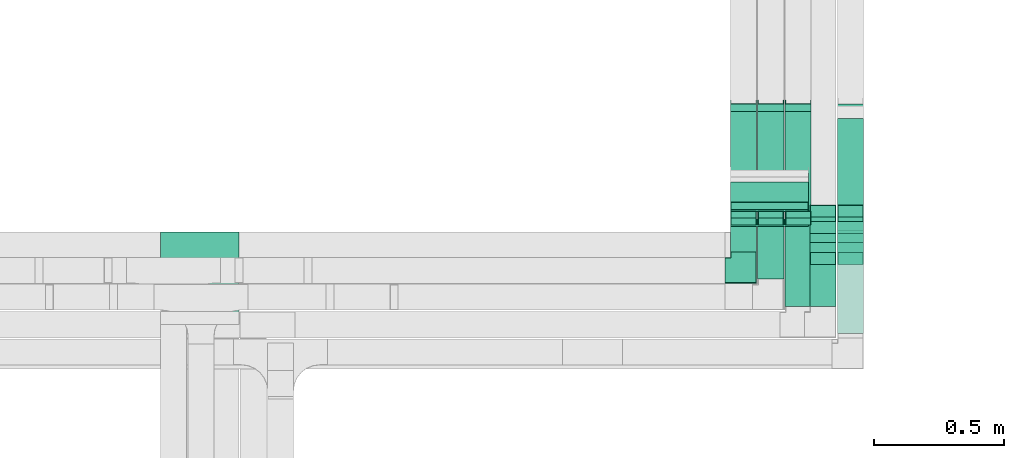
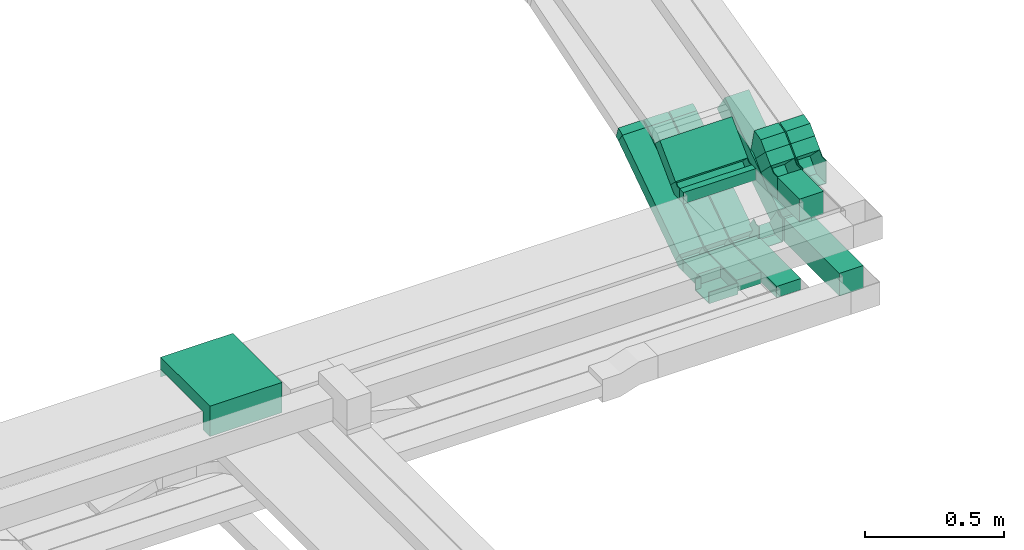
# One storey, part 8 of 18: 15 flow fittings, 13 flow segments.
"""IFC2X3 building model written with IfcOpenShell, lengths in millimetres."""

from ifc_helpers import new_model, entity, si_unit, converted_unit, derived_unit, direction, frame, frame_2d, origin, origin_2d_with_axis, place, context, subcontext, project, spatial, polyline, circle_curve, parameter, trimmed, segment, composite_curve, rectangle, outline, extrude, faceted_brep, source, transform, mapped, material, material_list, type_object, type_shapes, element, save


model = new_model("IFC2X3")

# Units and contexts
model_context = context("Model", 3, precision=0.01, world=origin(), true_north=direction((6.12303176911189e-17, 1.0)))
body_context = subcontext(model_context, "Body", "Model", "MODEL_VIEW")
ifc_project = project(units=[si_unit("LENGTHUNIT", "METRE", prefix="MILLI"), si_unit("AREAUNIT", "SQUARE_METRE"), si_unit("VOLUMEUNIT", "CUBIC_METRE"), converted_unit("PLANEANGLEUNIT", "DEGREE", entity("IfcRatioMeasure", 0.0174532925199433), si_unit("PLANEANGLEUNIT", "RADIAN"), dimensions=[0, 0, 0, 0, 0, 0, 0]), si_unit("MASSUNIT", "GRAM", prefix="KILO"), derived_unit("MASSDENSITYUNIT", [(si_unit("MASSUNIT", "GRAM", prefix="KILO"), 1), (si_unit("LENGTHUNIT", "METRE"), -3)]), derived_unit("MOMENTOFINERTIAUNIT", [(si_unit("LENGTHUNIT", "METRE"), 4)]), si_unit("TIMEUNIT", "SECOND"), si_unit("FREQUENCYUNIT", "HERTZ"), si_unit("THERMODYNAMICTEMPERATUREUNIT", "DEGREE_CELSIUS"), derived_unit("THERMALTRANSMITTANCEUNIT", [(si_unit("MASSUNIT", "GRAM", prefix="KILO"), 1), (si_unit("THERMODYNAMICTEMPERATUREUNIT", "KELVIN"), -1), (si_unit("TIMEUNIT", "SECOND"), -3)]), derived_unit("VOLUMETRICFLOWRATEUNIT", [(si_unit("LENGTHUNIT", "METRE"), 3), (si_unit("TIMEUNIT", "SECOND"), -1)]), derived_unit("MASSFLOWRATEUNIT", [(si_unit("MASSUNIT", "GRAM", prefix="KILO"), 1), (si_unit("TIMEUNIT", "SECOND"), -1)]), derived_unit("ROTATIONALFREQUENCYUNIT", [(si_unit("TIMEUNIT", "SECOND"), -1)]), si_unit("ELECTRICCURRENTUNIT", "AMPERE"), si_unit("ELECTRICVOLTAGEUNIT", "VOLT"), si_unit("POWERUNIT", "WATT"), si_unit("FORCEUNIT", "NEWTON", prefix="KILO"), si_unit("ILLUMINANCEUNIT", "LUX"), si_unit("LUMINOUSFLUXUNIT", "LUMEN"), si_unit("LUMINOUSINTENSITYUNIT", "CANDELA"), derived_unit("USERDEFINED", [(si_unit("MASSUNIT", "GRAM", prefix="KILO"), -1), (si_unit("LENGTHUNIT", "METRE"), -2), (si_unit("TIMEUNIT", "SECOND"), 3), (si_unit("LUMINOUSFLUXUNIT", "LUMEN"), 1)]), derived_unit("LINEARVELOCITYUNIT", [(si_unit("LENGTHUNIT", "METRE"), 1), (si_unit("TIMEUNIT", "SECOND"), -1)]), si_unit("PRESSUREUNIT", "PASCAL"), derived_unit("USERDEFINED", [(si_unit("LENGTHUNIT", "METRE"), -2), (si_unit("MASSUNIT", "GRAM", prefix="KILO"), 1), (si_unit("TIMEUNIT", "SECOND"), -2)]), derived_unit("LINEARFORCEUNIT", [(si_unit("MASSUNIT", "GRAM", prefix="KILO"), 1), (si_unit("LENGTHUNIT", "METRE"), 1), (si_unit("TIMEUNIT", "SECOND"), -2), (si_unit("LENGTHUNIT", "METRE"), -1)]), derived_unit("PLANARFORCEUNIT", [(si_unit("MASSUNIT", "GRAM", prefix="KILO"), 1), (si_unit("LENGTHUNIT", "METRE"), 1), (si_unit("TIMEUNIT", "SECOND"), -2), (si_unit("LENGTHUNIT", "METRE"), -2)])], contexts=[model_context])

# Site, building, storey
site_placement = place(None, frame((0.0, -0.00077364408347762, 0.0)))
site = spatial("IfcSite", under=ifc_project, at=site_placement, CompositionType="ELEMENT")
building_placement = place(site_placement, origin())
building = spatial("IfcBuilding", under=site, at=building_placement, CompositionType="ELEMENT")
storey_placement = place(building_placement, frame((0.0, 0.0, 19800.0)))
storey = spatial("IfcBuildingStorey", under=building, at=storey_placement, CompositionType="ELEMENT", Elevation=19800.0)

# Flow segments
cable_carrier_segment_type = type_object("IfcCableCarrierSegmentType", PredefinedType="CABLETRAYSEGMENT")
flow_segment_1_placement = place(storey_placement, frame((20600.2168010831, 9960.22583236333, 2600.0)))
element("IfcFlowSegment", 1, at=flow_segment_1_placement, inside=storey, type_object=cable_carrier_segment_type, context=body_context, shape_type="SweptSolid", body=[
    extrude(rectangle(XDim=396.146721820888, YDim=100.000000000003, at=frame_2d((0.0, 2.16715534406831e-12), x_axis=(1.0, 0.0))), frame((50.0, 198.073360910445, 0.0), z_axis=(0.0, 0.0, 1.0), x_axis=(0.0, 1.0, 0.0)), (0.0, 0.0, 1.0), 99.9999999999989),
])
flow_segment_2_placement = place(storey_placement, frame((20600.2168010831, 10396.2733517379, 2629.29514077132)))
element("IfcFlowSegment", 2, at=flow_segment_2_placement, inside=storey, type_object=cable_carrier_segment_type, context=body_context, shape_type="SweptSolid", body=[
    extrude(rectangle(XDim=100.000000000001, YDim=467.368346274404, at=frame_2d((-2.08899564313469e-12, -1.19371179607697e-12), x_axis=(0.0, 1.0))), frame((0.0, 221.692604815737, 172.12640989951), z_axis=(1.0, 0.0, 0.0), x_axis=(0.0, 0.829037572555048, 0.559192903470738)), (0.0, 0.0, 1.0), 100.000000000003),
])
flow_segment_3_placement = place(storey_placement, frame((20400.2168010831, 10064.235495744, 2600.0)))
element("IfcFlowSegment", 3, at=flow_segment_3_placement, inside=storey, type_object=cable_carrier_segment_type, context=body_context, shape_type="SweptSolid", body=[
    extrude(rectangle(XDim=311.24039895918, YDim=100.000000000003, at=origin_2d_with_axis()), frame((50.0, 155.620199479591, 0.0), z_axis=(0.0, 0.0, 1.0), x_axis=(0.0, -1.0, 0.0)), (0.0, 0.0, 1.0), 50.0000000000016),
])
flow_segment_4_placement = place(storey_placement, frame((20400.2168010831, 10401.3968696701, 2616.47295871295)))
element("IfcFlowSegment", 4, at=flow_segment_4_placement, inside=storey, type_object=cable_carrier_segment_type, context=body_context, shape_type="SweptSolid", body=[
    extrude(rectangle(XDim=49.9999999999964, YDim=493.947448455053, at=frame_2d((8.95283847057726e-13, -6.00408611717285e-13), x_axis=(0.0, 1.0))), frame((0.0, 218.730319405229, 158.831893245658), z_axis=(1.0, 0.0, 0.0), x_axis=(0.0, 0.829037572555015, 0.559192903470787)), (0.0, 0.0, 1.0), 100.000000000003),
])
flow_segment_5_placement = place(storey_placement, frame((20295.2168010831, 10401.3968696701, 2616.47295871295)))
element("IfcFlowSegment", 5, at=flow_segment_5_placement, inside=storey, type_object=cable_carrier_segment_type, context=body_context, shape_type="SweptSolid", body=[
    extrude(rectangle(XDim=49.9999999999977, YDim=493.947448455056, at=frame_2d((0.0, 0.0), x_axis=(0.0, 1.0))), frame((0.0, 218.730319405233, 158.831893245658), z_axis=(1.0, 0.0, 0.0), x_axis=(0.0, 0.829037572555018, 0.559192903470783)), (0.0, 0.0, 1.0), 100.000000000003),
])
flow_segment_6_placement = place(storey_placement, frame((20190.2168010831, 10401.3968696701, 2616.47295871295)))
element("IfcFlowSegment", 6, at=flow_segment_6_placement, inside=storey, type_object=cable_carrier_segment_type, context=body_context, shape_type="SweptSolid", body=[
    extrude(rectangle(XDim=49.9999999999964, YDim=493.947448455053, at=frame_2d((8.95283847057726e-13, -6.00408611717285e-13), x_axis=(0.0, 1.0))), frame((0.0, 218.730319405229, 158.831893245658), z_axis=(1.0, 0.0, 0.0), x_axis=(0.0, 0.829037572555015, 0.559192903470787)), (0.0, 0.0, 1.0), 100.000000000003),
])
flow_segment_7_placement = place(storey_placement, frame((20295.2168010831, 10169.8208448265, 2600.0)))
element("IfcFlowSegment", 7, at=flow_segment_7_placement, inside=storey, type_object=cable_carrier_segment_type, context=body_context, shape_type="SweptSolid", body=[
    extrude(rectangle(XDim=205.655049876662, YDim=100.000000000003, at=frame_2d((-1.08002495835535e-12, 0.0), x_axis=(1.0, 0.0))), frame((50.0, 102.827524938332, 0.0), z_axis=(0.0, 0.0, 1.0), x_axis=(0.0, -1.0, 0.0)), (0.0, 0.0, 1.0), 49.999999999993),
])
flow_segment_8_placement = place(storey_placement, frame((20190.2168010831, 10272.8422557896, 2600.0)))
element("IfcFlowSegment", 8, at=flow_segment_8_placement, inside=storey, type_object=cable_carrier_segment_type, context=body_context, shape_type="SweptSolid", body=[
    extrude(rectangle(XDim=102.633638913558, YDim=100.000000000003, at=origin_2d_with_axis()), frame((50.0, 51.3168194567835, 0.0), z_axis=(0.0, 0.0, 1.0), x_axis=(0.0, 1.0, 0.0)), (0.0, 0.0, 1.0), 49.9999999999973),
])
flow_segment_9_placement = place(storey_placement, frame((20600.2168010831, 10271.7762386117, 2948.93398282203)))
element("IfcFlowSegment", 9, at=flow_segment_9_placement, inside=storey, type_object=cable_carrier_segment_type, context=body_context, shape_type="SweptSolid", body=[
    extrude(rectangle(XDim=53.3220562203544, YDim=99.999999999999, at=origin_2d_with_axis()), frame((0.0, 54.2075328294396, 54.2075328294374), z_axis=(1.0, 0.0, 0.0), x_axis=(0.0, -0.707106781186487, -0.707106781186608)), (0.0, 0.0, 1.0), 100.000000000003),
])
flow_segment_10_placement = place(storey_placement, frame((20495.2168010831, 10064.235495744, 2900.0)))
element("IfcFlowSegment", 10, at=flow_segment_10_placement, inside=storey, type_object=cable_carrier_segment_type, context=body_context, shape_type="SweptSolid", body=[
    extrude(rectangle(XDim=160.114335996502, YDim=100.000000000003, at=frame_2d((-1.08713038571295e-12, -2.16715534406831e-12), x_axis=(1.0, 0.0))), frame((50.0, 80.0571679982565, 0.0), z_axis=(0.0, 0.0, 1.0), x_axis=(0.0, 1.0, 0.0)), (0.0, 0.0, 1.0), 100.000000000003),
])
flow_segment_11_placement = place(storey_placement, frame((20190.2168010831, 10370.1297639901, 2900.0)))
element("IfcFlowSegment", 11, at=flow_segment_11_placement, inside=storey, type_object=cable_carrier_segment_type, context=body_context, shape_type="SweptSolid", body=[
    extrude(rectangle(XDim=28.3940759827228, YDim=300.000000000001, at=frame_2d((0.0, -2.17426077142591e-12), x_axis=(1.0, 0.0))), frame((150.0, 14.1970379913842, 0.0), z_axis=(0.0, 0.0, 1.0), x_axis=(0.0, -1.0, 0.0)), (0.0, 0.0, 1.0), 49.999999999993),
])
flow_segment_12_placement = place(storey_placement, frame((20495.2168010831, 10271.7762386117, 2948.93398282202)))
element("IfcFlowSegment", 12, at=flow_segment_12_placement, inside=storey, type_object=cable_carrier_segment_type, context=body_context, shape_type="SweptSolid", body=[
    extrude(rectangle(XDim=53.322056220356, YDim=100.000000000002, at=frame_2d((2.29682939334452e-12, 7.67386154620908e-13), x_axis=(1.0, 0.0))), frame((0.0, 54.2075328294417, 54.2075328294417), z_axis=(1.0, 0.0, 0.0), x_axis=(0.0, -0.707106781186507, -0.707106781186588)), (0.0, 0.0, 1.0), 100.000000000008),
])
flow_segment_13_placement = place(storey_placement, frame((20190.2168010831, 10428.2725773144, 2926.96699141102)))
element("IfcFlowSegment", 13, at=flow_segment_13_placement, inside=storey, type_object=cable_carrier_segment_type, context=body_context, shape_type="SweptSolid", body=[
    extrude(rectangle(XDim=159.719975418482, YDim=49.9999999999957, at=frame_2d((-2.29505303650512e-12, -7.65609797781508e-13), x_axis=(1.0, 0.0))), frame((0.0, 74.147208384338, 74.1472083843467), z_axis=(1.0, 0.0, 0.0), x_axis=(0.0, -0.707106781186473, -0.707106781186622)), (0.0, 0.0, 1.0), 300.000000000001),
])

# Flow fittings
ifc_material = material()
cable_carrier_fitting_type_1 = type_object("IfcCableCarrierFittingType", PredefinedType="NOTDEFINED", material=ifc_material)
shared_shape_1 = source(origin(), body_context, "Body", "Brep", [
    faceted_brep([(-70.0, 50.0, -25.0), (-70.0, -50.0, -25.0), (-70.0, -50.0, 25.0), (-70.0, -47.4600000101598, 25.0), (-70.0, -47.4600000101598, -22.4600000101565), (-70.0, 47.4600000101602, -22.4600000101565), (-70.0, 47.4600000101602, 25.0), (-70.0, 50.0, 25.0), (-50.0, 50.0, -25.0), (-50.0, 70.0, -25.0), (50.0, 70.0, -25.0), (50.0, -50.0, -25.0), (50.0, -50.0, 25.0), (50.0, 70.0, 25.0), (47.4600000101603, 70.0, 25.0), (47.4600000101596, -47.4600000101602, 25.0), (47.4600000101596, -47.4600000101602, -22.4600000101565), (47.4600000101603, 70.0, -22.4600000101565), (-47.4600000101597, 70.0, -22.4600000101565), (-47.4600000101602, 47.4600000101602, -22.4600000101565), (-47.4600000101602, 47.4600000101602, 25.0), (-47.4600000101597, 70.0, 25.0), (-50.0, 70.0, 25.0), (-50.0, 50.0, 25.0)], [[[0, 1, 2, 3, 4, 5, 6, 7]], [[1, 0, 8, 9, 10, 11]], [[2, 1, 11, 12]], [[3, 2, 12, 13, 14, 15]], [[4, 3, 15, 16]], [[5, 4, 16, 17, 18, 19]], [[6, 5, 19, 20]], [[7, 6, 20, 21, 22, 23]], [[0, 7, 23, 8]], [[9, 22, 21, 18, 17, 14, 13, 10]], [[12, 11, 10, 13]], [[16, 15, 14, 17]], [[20, 19, 18, 21]], [[8, 23, 22, 9]]]),
])
type_shapes(cable_carrier_fitting_type_1, [shared_shape_1])
flow_fitting_1_placement = place(storey_placement, frame((20240.2168010831, 10202.8422557896, 2625.0)))
element("IfcFlowFitting", 14, at=flow_fitting_1_placement, inside=storey, type_object=cable_carrier_fitting_type_1, material=ifc_material, context=body_context, shape_type="MappedRepresentation", body=[
    mapped(shared_shape_1, transform((0.0, 0.0, 0.0), scale=1.0)),
])
cable_carrier_fitting_type_2 = type_object("IfcCableCarrierFittingType", PredefinedType="NOTDEFINED", material=ifc_material)
shared_shape_2 = source(origin(), body_context, "Body", "Brep", [
    faceted_brep([(-37.1017215531618, -50.0, 50.0), (-37.1017215531615, 50.0, 50.0), (-37.1017215531615, 50.0, 47.4600000101635), (-37.1017215531618, -47.4600000101599, 47.4600000101635), (-37.1017215531618, -47.4600000101599, -47.4600000101565), (-37.1017215531615, 50.0, -47.4600000101565), (-37.1017215531615, 50.0, -50.0), (-37.1017215531618, -50.0, -50.0), (58.7183663475855, -20.7048592286738, 50.0), (58.7183663475855, -20.7048592286738, -50.0), (2.79907600050685, 62.1988980268277, -50.0), (2.79907600050686, 62.1988980268277, -47.4600000101565), (57.2980163784511, -18.5991038028071, -47.4600000101565), (57.2980163784511, -18.5991038028071, 47.4600000101635), (2.79907600050685, 62.1988980268277, 47.4600000101635), (2.79907600050686, 62.1988980268277, 50.0), (15.2865340729347, -50.0, 50.0), (-15.2865340729339, 50.0, 50.0), (-15.2865340729339, 50.0, 47.4600000101635), (14.5099781451358, -47.46000001016, 47.4600000101635), (14.5099781451358, -47.46000001016, -47.4600000101565), (-15.2865340729339, 50.0, -47.4600000101565), (-15.2865340729339, 50.0, -50.0), (15.2865340729346, -50.0, -50.0)], [[[0, 1, 2, 3, 4, 5, 6, 7]], [[8, 9, 10, 11, 12, 13, 14, 15]], [[1, 0, 16, 8, 15, 17]], [[2, 1, 17, 18]], [[3, 2, 18, 14, 13, 19]], [[4, 3, 19, 20]], [[5, 4, 20, 12, 11, 21]], [[6, 5, 21, 22]], [[7, 6, 22, 10, 9, 23]], [[0, 7, 23, 16]], [[18, 17, 15, 14]], [[20, 19, 13, 12]], [[22, 21, 11, 10]], [[16, 23, 9, 8]]]),
])
type_shapes(cable_carrier_fitting_type_2, [shared_shape_2])
for number, where, z_axis, x_axis in (
    (15, (20650.2168010831, 10393.4742757374, 2650.0), (1.0, 0.0, 0.0), (0.0, 1.0, 0.0)),
    (16, (20545.2168010831, 10393.4742757374, 2650.0), (1.0, 0.0, 0.0), (0.0, 1.0, 0.0)),
):
    element("IfcFlowFitting", number, at=place(storey_placement, frame(where, z_axis=z_axis, x_axis=x_axis)), inside=storey, type_object=cable_carrier_fitting_type_2, material=ifc_material, context=body_context, shape_type="MappedRepresentation", body=[
        mapped(shared_shape_2, transform((0.0, 0.0, 0.0), scale=1.0)),
    ])
cable_carrier_fitting_type_3 = type_object("IfcCableCarrierFittingType", PredefinedType="NOTDEFINED", material=ifc_material)
shared_shape_3 = source(origin(), body_context, "Body", "Brep", [
    faceted_brep([(-12.9278920099056, -25.0, 50.0), (-12.9278920099055, 25.0, 50.0), (-12.9278920099055, 25.0, 47.4600000101635), (-12.9278920099056, -22.46000001016, 47.4600000101635), (-12.9278920099056, -22.46000001016, -47.4600000101565), (-12.9278920099055, 25.0, -47.4600000101565), (-12.9278920099055, 25.0, -50.0), (-12.9278920099056, -25.0, -50.0), (19.4620887269069, -20.3311951002845, 50.0), (19.4620887269069, -20.3311951002845, -50.0), (5.34113554835774, 27.6333614110524, -50.0), (5.34113554835774, 27.6333614110524, -47.4600000101565), (18.744744308306, -17.8945956392549, -47.4600000101565), (18.744744308306, -17.894595639255, 47.4600000101635), (5.34113554835774, 27.6333614110524, 47.4600000101635), (5.34113554835774, 27.6333614110524, 50.0), (3.60358727723034, -25.0, 50.0), (-3.60358727722956, 25.0, 50.0), (-3.60358727722956, 25.0, 47.4600000101635), (3.23746281132821, -22.46000001016, 47.4600000101635), (3.23746281132821, -22.46000001016, -47.4600000101565), (-3.60358727722956, 25.0, -47.4600000101565), (-3.60358727722956, 25.0, -50.0), (3.60358727723027, -25.0, -50.0)], [[[0, 1, 2, 3, 4, 5, 6, 7]], [[8, 9, 10, 11, 12, 13, 14, 15]], [[1, 0, 16, 8, 15, 17]], [[2, 1, 17, 18]], [[3, 2, 18, 14, 13, 19]], [[4, 3, 19, 20]], [[5, 4, 20, 12, 11, 21]], [[6, 5, 21, 22]], [[7, 6, 22, 10, 9, 23]], [[0, 7, 23, 16]], [[18, 17, 15, 14]], [[20, 19, 13, 12]], [[22, 21, 11, 10]], [[16, 23, 9, 8]]]),
])
type_shapes(cable_carrier_fitting_type_3, [shared_shape_3])
for number, where, z_axis, x_axis in (
    (17, (20450.2168010831, 10835.5953941039, 2920.63999135916), (-1.0, 0.0, 0.0), (0.0, 0.829037572555048, 0.559192903470738)),
    (18, (20345.2168010831, 10835.5953941039, 2920.63999135916), (-1.0, 0.0, 0.0), (0.0, 0.829037572555048, 0.559192903470738)),
    (19, (20240.2168010831, 10835.5953941039, 2920.63999135916), (-1.0, 0.0, 0.0), (0.0, 0.829037572555048, 0.559192903470738)),
):
    element("IfcFlowFitting", number, at=place(storey_placement, frame(where, z_axis=z_axis, x_axis=x_axis)), inside=storey, type_object=cable_carrier_fitting_type_3, material=ifc_material, context=body_context, shape_type="MappedRepresentation", body=[
        mapped(shared_shape_3, transform((0.0, 0.0, 0.0), scale=1.0)),
    ])
cable_carrier_fitting_type_4 = type_object("IfcCableCarrierFittingType", PredefinedType="NOTDEFINED", material=ifc_material)
shared_shape_4 = source(origin(), body_context, "Body", "Brep", [
    faceted_brep([(-21.8151874802274, -25.0, 50.0), (-21.8151874802273, 25.0, 50.0), (-21.8151874802273, 25.0, 47.4600000101635), (-21.8151874802274, -22.4600000101599, 47.4600000101635), (-21.8151874802274, -22.4600000101599, -47.4600000101565), (-21.8151874802273, 25.0, -47.4600000101565), (-21.8151874802273, 25.0, -50.0), (-21.8151874802274, -25.0, -50.0), (32.0654326602108, -8.52704128704767, 50.0), (32.0654326602108, -8.52704128704768, -50.0), (4.10578748667152, 32.9248373407031, -50.0), (4.10578748667152, 32.9248373407031, -47.4600000101565), (30.6450826910764, -6.42128586118095, -47.4600000101565), (30.6450826910764, -6.42128586118094, 47.4600000101635), (4.10578748667152, 32.9248373407031, 47.4600000101635), (4.10578748667152, 32.9248373407031, 50.0), (7.64326703646762, -25.0, 50.0), (-7.64326703646677, 25.0, 50.0), (-7.64326703646678, 25.0, 47.4600000101635), (6.86671110866865, -22.46000001016, 47.4600000101635), (6.86671110866865, -22.46000001016, -47.4600000101565), (-7.64326703646677, 25.0, -47.4600000101565), (-7.64326703646677, 25.0, -50.0), (7.64326703646748, -25.0, -50.0)], [[[0, 1, 2, 3, 4, 5, 6, 7]], [[8, 9, 10, 11, 12, 13, 14, 15]], [[1, 0, 16, 8, 15, 17]], [[2, 1, 17, 18]], [[3, 2, 18, 14, 13, 19]], [[4, 3, 19, 20]], [[5, 4, 20, 12, 11, 21]], [[6, 5, 21, 22]], [[7, 6, 22, 10, 9, 23]], [[0, 7, 23, 16]], [[18, 17, 15, 14]], [[20, 19, 13, 12]], [[22, 21, 11, 10]], [[16, 23, 9, 8]]]),
])
type_shapes(cable_carrier_fitting_type_4, [shared_shape_4])
for number, where, z_axis, x_axis in (
    (20, (20450.2168010831, 10397.2910821834, 2625.0), (-1.0, 0.0, 0.0), (0.0, -0.829037572555015, -0.559192903470787)),
    (21, (20345.2168010831, 10397.2910821834, 2625.0), (-1.0, 0.0, 0.0), (0.0, -0.829037572555018, -0.559192903470783)),
    (22, (20240.2168010831, 10397.2910821834, 2625.0), (-1.0, 0.0, 0.0), (0.0, -0.829037572555015, -0.559192903470787)),
):
    element("IfcFlowFitting", number, at=place(storey_placement, frame(where, z_axis=z_axis, x_axis=x_axis)), inside=storey, type_object=cable_carrier_fitting_type_4, material=ifc_material, context=body_context, shape_type="MappedRepresentation", body=[
        mapped(shared_shape_4, transform((0.0, 0.0, 0.0), scale=1.0)),
    ])
cable_carrier_fitting_type_5 = type_object("IfcCableCarrierFittingType", PredefinedType="NOTDEFINED", material=ifc_material)
shared_shape_5 = source(origin(), body_context, "Body", "Brep", [
    faceted_brep([(-34.1580746382116, -50.0, 50.0), (-34.1580746382113, 50.0, 50.0), (-34.1580746382113, 50.0, 47.4600000101635), (-34.1580746382116, -47.4600000101599, 47.4600000101635), (-34.1580746382116, -47.4600000101599, -47.4600000101565), (-34.1580746382113, 50.0, -47.4600000101565), (-34.1580746382113, 50.0, -50.0), (-34.1580746382116, -50.0, -50.0), (55.0485008869463, -25.2276953582687, 50.0), (55.0485008869463, -25.2276953582687, -50.0), (3.48558725032221, 60.4534924095374, -50.0), (3.48558725032222, 60.4534924095374, -47.4600000101565), (53.7388028858149, -23.0513931976716, -47.4600000101565), (53.7388028858149, -23.0513931976716, 47.4600000101635), (3.48558725032221, 60.4534924095374, 47.4600000101635), (3.48558725032221, 60.4534924095374, 50.0), (13.884797446768, -50.0, 50.0), (-13.8847974467671, 50.0, 50.0), (-13.8847974467671, 50.0, 47.4600000101635), (13.1794497392934, -47.46000001016, 47.4600000101635), (13.1794497392934, -47.46000001016, -47.4600000101565), (-13.8847974467671, 50.0, -47.4600000101565), (-13.8847974467671, 50.0, -50.0), (13.8847974467678, -50.0, -50.0)], [[[0, 1, 2, 3, 4, 5, 6, 7]], [[8, 9, 10, 11, 12, 13, 14, 15]], [[1, 0, 16, 8, 15, 17]], [[2, 1, 17, 18]], [[3, 2, 18, 14, 13, 19]], [[4, 3, 19, 20]], [[5, 4, 20, 12, 11, 21]], [[6, 5, 21, 22]], [[7, 6, 22, 10, 9, 23]], [[0, 7, 23, 16]], [[18, 17, 15, 14]], [[20, 19, 13, 12]], [[22, 21, 11, 10]], [[16, 23, 9, 8]]]),
])
type_shapes(cable_carrier_fitting_type_5, [shared_shape_5])
for number, where, z_axis, x_axis in (
    (23, (20650.2168010831, 10368.9893714202, 3046.14711563054), (-1.0, 0.0, 0.0), (0.0, 0.707106781186483, 0.707106781186612)),
    (24, (20545.2168010831, 10368.9893714202, 3046.14711563053), (-1.0, 0.0, 0.0), (0.0, 0.707106781186507, 0.707106781186588)),
):
    element("IfcFlowFitting", number, at=place(storey_placement, frame(where, z_axis=z_axis, x_axis=x_axis)), inside=storey, type_object=cable_carrier_fitting_type_5, material=ifc_material, context=body_context, shape_type="MappedRepresentation", body=[
        mapped(shared_shape_5, transform((0.0, 0.0, 0.0), scale=1.0)),
    ])
cable_carrier_fitting_type_6 = type_object("IfcCableCarrierFittingType", PredefinedType="NOTDEFINED", material=ifc_material)
shared_shape_6 = source(origin(), body_context, "Body", "Brep", [
    faceted_brep([(-48.4924240491818, -50.0, 50.0), (-48.4924240491815, 50.0, 50.0), (-48.4924240491815, 50.0, 47.4600000101635), (-48.4924240491818, -47.4600000101598, 47.4600000101635), (-48.4924240491818, -47.4600000101598, -47.4600000101565), (-48.4924240491815, 50.0, -47.4600000101565), (-48.4924240491815, 50.0, -50.0), (-48.4924240491818, -50.0, -50.0), (69.6446609406784, -1.06601717796952, 50.0), (69.6446609406784, -1.06601717796953, -50.0), (-1.06601717798446, 69.6446609406772, -50.0), (-1.06601717798447, 69.6446609406772, -47.4600000101565), (67.8486097236486, 0.730034039059905, -47.4600000101565), (67.8486097236486, 0.730034039059901, 47.4600000101635), (-1.06601717798446, 69.6446609406772, 47.4600000101635), (-1.06601717798447, 69.6446609406772, 50.0), (20.7106781186586, -50.0, 50.0), (-20.7106781186577, 50.0, 50.0), (-20.7106781186577, 50.0, 47.4600000101635), (19.658575674439, -47.4600000101601, 47.4600000101635), (19.658575674439, -47.4600000101601, -47.4600000101565), (-20.7106781186577, 50.0, -47.4600000101565), (-20.7106781186577, 50.0, -50.0), (20.7106781186584, -50.0, -50.0)], [[[0, 1, 2, 3, 4, 5, 6, 7]], [[8, 9, 10, 11, 12, 13, 14, 15]], [[1, 0, 16, 8, 15, 17]], [[2, 1, 17, 18]], [[3, 2, 18, 14, 13, 19]], [[4, 3, 19, 20]], [[5, 4, 20, 12, 11, 21]], [[6, 5, 21, 22]], [[7, 6, 22, 10, 9, 23]], [[0, 7, 23, 16]], [[18, 17, 15, 14]], [[20, 19, 13, 12]], [[22, 21, 11, 10]], [[16, 23, 9, 8]]]),
])
type_shapes(cable_carrier_fitting_type_6, [shared_shape_6])
for number, where, z_axis, x_axis in (
    (25, (20545.2168010831, 10272.8422557897, 2950.0), (1.0, 0.0, 0.0), (0.0, 1.0, 0.0)),
    (26, (20650.2168010831, 10272.8422557897, 2950.0), (-1.0, 0.0, 0.0), (0.0, -0.707106781186487, -0.707106781186608)),
):
    element("IfcFlowFitting", number, at=place(storey_placement, frame(where, z_axis=z_axis, x_axis=x_axis)), inside=storey, type_object=cable_carrier_fitting_type_6, material=ifc_material, context=body_context, shape_type="MappedRepresentation", body=[
        mapped(shared_shape_6, transform((0.0, 0.0, 0.0), scale=1.0)),
    ])
cable_carrier_fitting_type_7 = type_object("IfcCableCarrierFittingType", PredefinedType="NOTDEFINED", material=ifc_material)
shared_shape_7 = source(origin(), body_context, "Body", "Brep", [
    faceted_brep([(-27.7817459305236, -25.0, 150.0), (-27.7817459305234, 25.0, 150.0), (-27.7817459305234, 25.0, 147.460000010164), (-27.7817459305236, -22.4600000101599, 147.460000010164), (-27.7817459305236, -22.4600000101599, -147.460000010156), (-27.7817459305234, 25.0, -147.460000010156), (-27.7817459305234, 25.0, -150.0), (-27.7817459305236, -25.0, -150.0), (37.3223304703394, 1.96699141101549, 150.0), (37.3223304703394, 1.96699141101549, -150.0), (1.96699141100793, 37.3223304703388, -150.0), (1.96699141100793, 37.3223304703388, -147.460000010156), (35.5262792533096, 3.76304262804491, -147.460000010156), (35.5262792533096, 3.76304262804491, 147.460000010164), (1.96699141100793, 37.3223304703388, 147.460000010164), (1.96699141100793, 37.3223304703388, 150.0), (10.3553390593296, -25.0, 150.0), (-10.3553390593287, 25.0, 150.0), (-10.3553390593287, 25.0, 147.460000010164), (9.30323661510995, -22.46000001016, 147.460000010164), (9.30323661510995, -22.46000001016, -147.460000010156), (-10.3553390593287, 25.0, -147.460000010156), (-10.3553390593287, 25.0, -150.0), (10.3553390593294, -25.0, -150.0)], [[[0, 1, 2, 3, 4, 5, 6, 7]], [[8, 9, 10, 11, 12, 13, 14, 15]], [[1, 0, 16, 8, 15, 17]], [[2, 1, 17, 18]], [[3, 2, 18, 14, 13, 19]], [[4, 3, 19, 20]], [[5, 4, 20, 12, 11, 21]], [[6, 5, 21, 22]], [[7, 6, 22, 10, 9, 23]], [[0, 7, 23, 16]], [[18, 17, 15, 14]], [[20, 19, 13, 12]], [[22, 21, 11, 10]], [[16, 23, 9, 8]]]),
])
type_shapes(cable_carrier_fitting_type_7, [shared_shape_7])
flow_fitting_2_placement = place(storey_placement, frame((20340.2168010831, 10426.3055859034, 2925.0), z_axis=(-1.0, 0.0, 0.0), x_axis=(0.0, -0.707106781186473, -0.707106781186622)))
element("IfcFlowFitting", 27, at=flow_fitting_2_placement, inside=storey, type_object=cable_carrier_fitting_type_7, material=ifc_material, context=body_context, shape_type="MappedRepresentation", body=[
    mapped(shared_shape_7, transform((0.0, 0.0, 0.0), scale=1.0)),
])
ifc_material_list_1 = material_list([ifc_material, ifc_material, ifc_material, ifc_material, ifc_material])
ifc_material_list_2 = material_list([ifc_material, ifc_material, ifc_material, ifc_material, ifc_material])
cable_carrier_fitting_type_8 = type_object("IfcCableCarrierFittingType", PredefinedType="NOTDEFINED", material=ifc_material_list_2)
shared_shape_8 = source(origin(), body_context, "Body", "SweptSolid", [
    extrude(outline(composite_curve([segment(polyline([(-61.8571428571423, -231.428571428572), (-7.85714285714297, -231.428571428572)]), True, "CONTINUOUS"), segment(polyline([(-7.85714285714297, -231.428571428572), (-7.85714285714358, 68.5714285714291)]), True, "CONTINUOUS"), segment(trimmed(circle_curve(frame_2d((-2.85714285714358, 68.5714285714291), x_axis=(0.0, -1.0)), 5.0), [parameter(180.0)], [parameter(270.0)], True, "PARAMETER"), False, "CONTINUOUS"), segment(polyline([(-2.85714285714357, 73.5714285714285), (71.1428571428573, 73.5714285714285)]), True, "CONTINUOUS"), segment(polyline([(71.1428571428573, 73.5714285714285), (71.1428571428573, 123.571428571428)]), True, "CONTINUOUS"), segment(polyline([(71.1428571428573, 123.571428571428), (-61.8571428571423, 123.571428571428)]), True, "CONTINUOUS"), segment(polyline([(-61.8571428571423, 123.571428571428), (-61.8571428571423, -231.428571428572)]), True, "CONTINUOUS")], self_intersect=False)), frame((-81.4285714285714, -150.0, 17.1428571428574), z_axis=(0.0, 1.0, 0.0), x_axis=(0.0, 0.0, -1.0)), (0.0, 0.0, 1.0), 0.799999999999987),
    extrude(rectangle(XDim=0.799999999999852, YDim=300.0, at=origin_2d_with_axis()), frame((149.6, 0.0, -7.4999999999326), z_axis=(0.0, 0.0, 1.0), x_axis=(-1.0, 0.0, 0.0)), (0.0, 0.0, 1.0), 86.4999999999327),
    extrude(rectangle(XDim=355.0, YDim=300.0, at=origin_2d_with_axis()), frame((-27.4999999999999, 0.0, 78.1999999999995), z_axis=(0.0, 0.0, 1.0), x_axis=(-1.0, 0.0, 0.0)), (0.0, 0.0, 1.0), 0.800000000000055),
    extrude(rectangle(XDim=0.79999999999992, YDim=298.4, at=frame_2d((-1.69309011255336e-14, 0.0), x_axis=(1.0, 0.0))), frame((-204.6, 0.0, -54.0), z_axis=(0.0, 0.0, 1.0), x_axis=(-1.0, 0.0, 0.0)), (0.0, 0.0, 1.0), 132.999999999999),
    extrude(outline(composite_curve([segment(polyline([(-61.8571428571426, -231.428571428571), (-7.85714285714288, -231.428571428571)]), True, "CONTINUOUS"), segment(polyline([(-7.85714285714288, -231.428571428571), (-7.85714285714289, 68.5714285714286)]), True, "CONTINUOUS"), segment(trimmed(circle_curve(frame_2d((-2.85714285714289, 68.5714285714286), x_axis=(0.0, -1.0)), 5.0), [parameter(180.0)], [parameter(270.0)], True, "PARAMETER"), False, "CONTINUOUS"), segment(polyline([(-2.85714285714286, 73.5714285714286), (71.1428571428569, 73.5714285714286)]), True, "CONTINUOUS"), segment(polyline([(71.1428571428569, 73.5714285714286), (71.1428571428569, 123.571428571429)]), True, "CONTINUOUS"), segment(polyline([(71.1428571428569, 123.571428571429), (-61.8571428571426, 123.571428571429)]), True, "CONTINUOUS"), segment(polyline([(-61.8571428571426, 123.571428571429), (-61.8571428571426, -231.428571428571)]), True, "CONTINUOUS")], self_intersect=False)), frame((-81.4285714285709, 149.2, 17.1428571428576), z_axis=(0.0, 1.0, 0.0), x_axis=(0.0, 0.0, -1.0)), (0.0, 0.0, 1.0), 0.799999999999784),
])
type_shapes(cable_carrier_fitting_type_8, [shared_shape_8])
flow_fitting_3_placement = place(storey_placement, frame((18157.1440474966, 10200.1297639901, 2925.0), z_axis=(0.0, 0.0, 1.0), x_axis=(0.0, 1.0, 0.0)))
element("IfcFlowFitting", 28, at=flow_fitting_3_placement, inside=storey, type_object=cable_carrier_fitting_type_8, material=ifc_material_list_1, Name="470_DKC_S5_vertical T-shaped cover", context=body_context, shape_type="MappedRepresentation", body=[
    mapped(shared_shape_8, transform((0.0, 0.0, 0.0), scale=1.0)),
])

save(model, "model.ifc")
